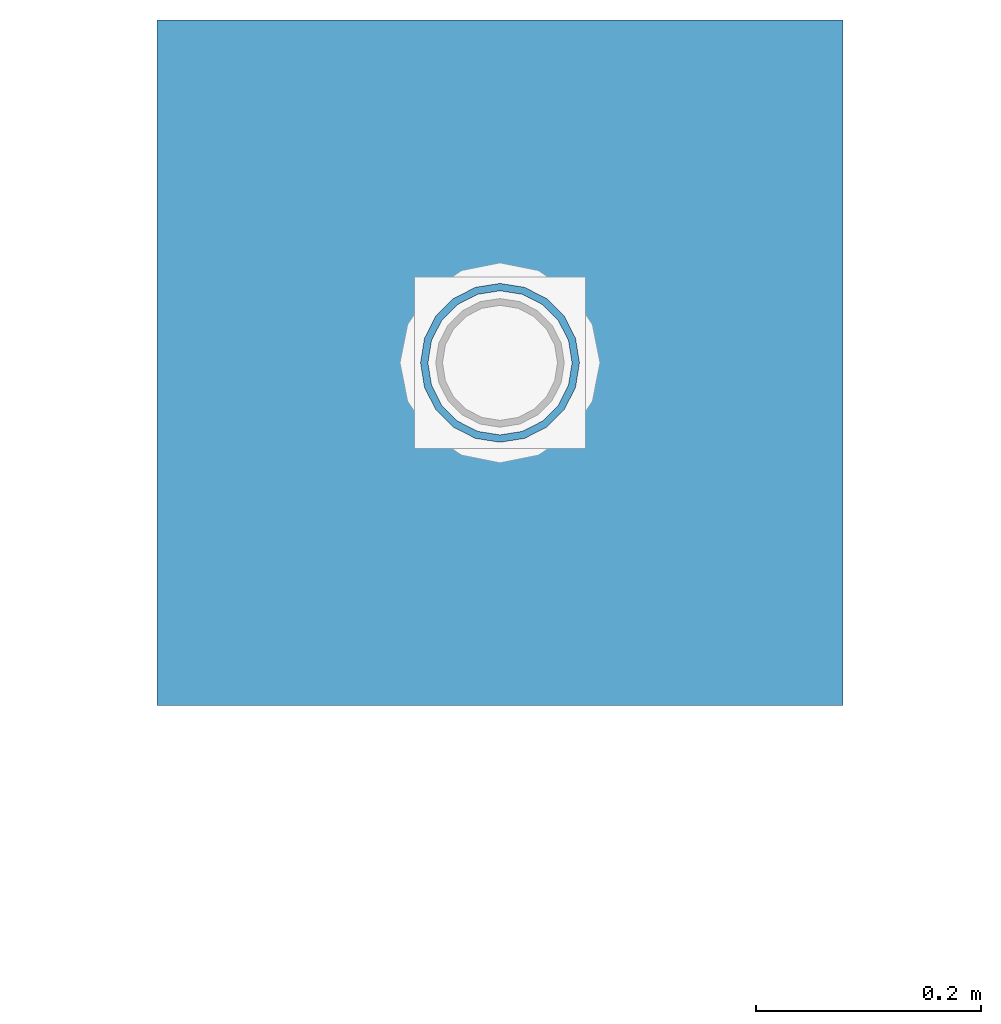
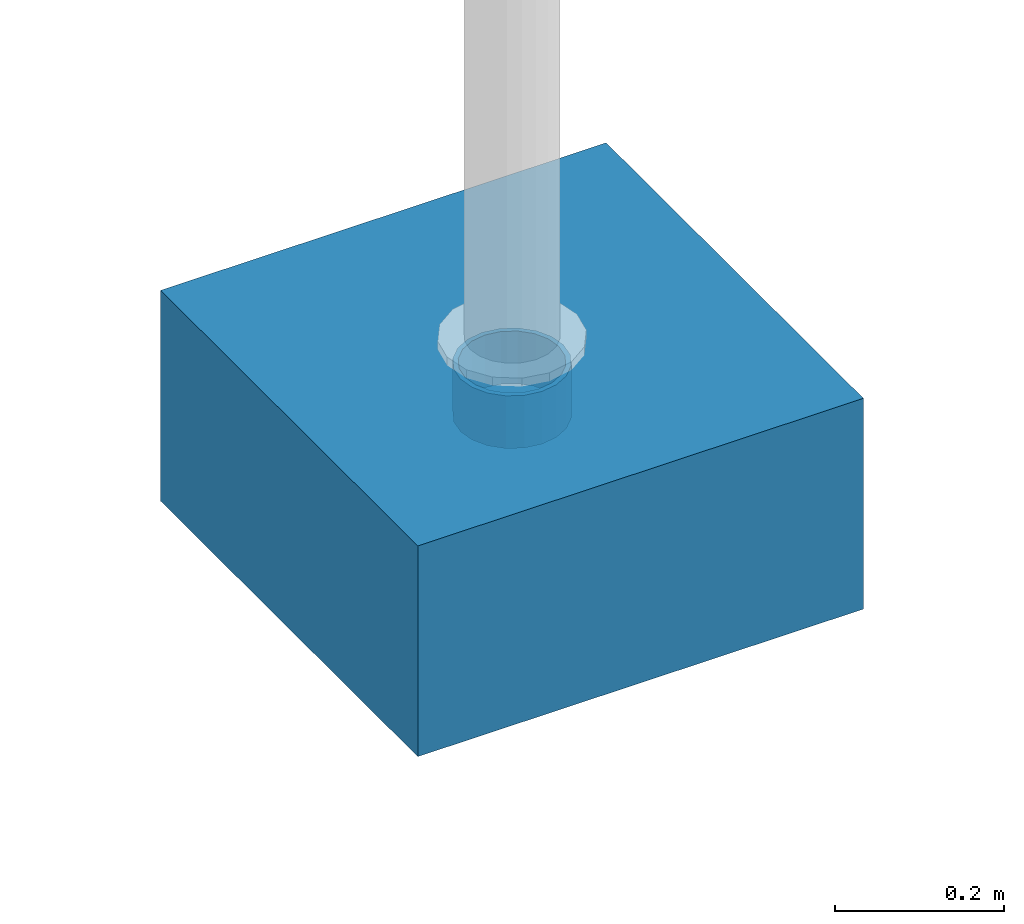
# One storey, part 1543 of 3843: 2 columns, 2 elements without a shape of their own.
"""IFC2X3 building model written with IfcOpenShell, lengths in millimetres."""

from ifc_helpers import new_model, si_unit, frame, origin_with_axes, place, context, subcontext, project, spatial, faceted_brep, material, type_object, element, aggregate, save


model = new_model("IFC2X3")

# Units and contexts
model_context = context("Model", 3, precision=1e-05, world=origin_with_axes())
body_context = subcontext(model_context, "Body", "Model", "MODEL_VIEW")
ifc_project = project(units=[si_unit("LENGTHUNIT", "METRE", prefix="MILLI"), si_unit("AREAUNIT", "SQUARE_METRE"), si_unit("VOLUMEUNIT", "CUBIC_METRE"), si_unit("MASSUNIT", "GRAM", prefix="KILO"), si_unit("TIMEUNIT", "SECOND"), si_unit("PLANEANGLEUNIT", "RADIAN"), si_unit("SOLIDANGLEUNIT", "STERADIAN"), si_unit("THERMODYNAMICTEMPERATUREUNIT", "DEGREE_CELSIUS"), si_unit("LUMINOUSINTENSITYUNIT", "LUMEN")], contexts=[model_context])

# Site, building, storey
site_placement = place(None, origin_with_axes())
site = spatial("IfcSite", under=ifc_project, at=site_placement, CompositionType="ELEMENT")
building_placement = place(site_placement, origin_with_axes())
building = spatial("IfcBuilding", under=site, at=building_placement, Name="Undefined", CompositionType="ELEMENT")
storey_placement = place(building_placement, origin_with_axes())
storey = spatial("IfcBuildingStorey", under=building, at=storey_placement, Name="Undefined", CompositionType="ELEMENT", Elevation=0.0)

# Assembly, column
assembly_1_placement = place(storey_placement, origin_with_axes())
assembly_1 = element("IfcElementAssembly", 1, at=assembly_1_placement, inside=storey, Name="PLATE", AssemblyPlace="NOTDEFINED", PredefinedType="RIGID_FRAME")
ifc_material_1 = material()
column_type_1 = type_object("IfcColumnType", Name="PIPE5SCH40", PredefinedType="NOTDEFINED")
column_1_placement = place(assembly_1_placement, frame((12915.2250135243, 106839.149780512, 30378.4), z_axis=(-1.0, 0.0, 0.0), x_axis=(0.0, 0.0, 1.0)))
column_1 = element("IfcColumn", 2, at=column_1_placement, type_object=column_type_1, material=ifc_material_1, Name="PIPE_SLEEVE", ObjectType="PIPE5SCH40", context=body_context, shape_type="Brep", body=[
    faceted_brep([(0.0, -64.0587999999998, 0.0), (0.0, -60.9235391660477, 19.7952578392724), (76.2000000000007, -60.9235391660477, 19.7952578392724), (76.2000000000007, -64.0587999999998, 0.0), (0.0, -51.8246578392655, 37.6528179195593), (76.2000000000007, -51.8246578392655, 37.6528179195593), (0.0, -37.6528179195529, 51.8246578392718), (76.2000000000007, -37.6528179195529, 51.8246578392718), (0.0, -19.795257839266, 60.9235391660477), (76.2000000000007, -19.795257839266, 60.9235391660477), (0.0, 0.0, 64.0587999999989), (76.2000000000007, 0.0, 64.0587999999989), (0.0, 19.795257839266, 60.9235391660477), (76.2000000000007, 19.795257839266, 60.9235391660477), (0.0, 37.6528179195529, 51.8246578392718), (76.2000000000007, 37.6528179195529, 51.8246578392718), (0.0, 51.8246578392655, 37.6528179195593), (76.2000000000007, 51.8246578392655, 37.6528179195593), (0.0, 60.9235391660477, 19.7952578392724), (76.2000000000007, 60.9235391660477, 19.7952578392724), (0.0, 64.0587999999998, 0.0), (76.2000000000007, 64.0587999999998, 0.0), (0.0, 60.9235391660477, -19.7952578392724), (76.2000000000007, 60.9235391660477, -19.7952578392724), (0.0, 51.8246578392655, -37.6528179195593), (76.2000000000007, 51.8246578392655, -37.6528179195593), (0.0, 37.6528179195529, -51.8246578392718), (76.2000000000007, 37.6528179195529, -51.8246578392718), (0.0, 19.795257839266, -60.9235391660477), (76.2000000000007, 19.795257839266, -60.9235391660477), (0.0, 0.0, -64.0587999999989), (76.2000000000007, 0.0, -64.0587999999989), (0.0, -19.795257839266, -60.9235391660477), (76.2000000000007, -19.795257839266, -60.9235391660477), (0.0, -37.6528179195529, -51.8246578392718), (76.2000000000007, -37.6528179195529, -51.8246578392718), (0.0, -51.8246578392655, -37.6528179195593), (76.2000000000007, -51.8246578392655, -37.6528179195593), (0.0, -60.9235391660477, -19.7952578392724), (76.2000000000007, -60.9235391660477, -19.7952578392724), (0.0, -70.6120000000001, 0.0), (0.0, -67.1560027286332, -21.8203080068051), (76.2000000000007, -67.1560027286332, -21.8203080068051), (76.2000000000007, -70.6120000000001, 0.0), (0.0, -57.1263080068038, -41.5046922348702), (76.2000000000007, -57.1263080068038, -41.5046922348702), (0.0, -41.5046922348765, -57.126308006802), (76.2000000000007, -41.5046922348765, -57.126308006802), (0.0, -21.8203080068042, -67.1560027286323), (76.2000000000007, -21.8203080068042, -67.1560027286323), (0.0, 0.0, -70.6119999999937), (76.2000000000007, 0.0, -70.6119999999937), (0.0, 21.8203080068042, -67.1560027286323), (76.2000000000007, 21.8203080068042, -67.1560027286323), (0.0, 41.5046922348765, -57.126308006802), (76.2000000000007, 41.5046922348765, -57.126308006802), (0.0, 57.1263080068038, -41.5046922348702), (76.2000000000007, 57.1263080068038, -41.5046922348702), (0.0, 67.1560027286332, -21.8203080068051), (76.2000000000007, 67.1560027286332, -21.8203080068051), (0.0, 70.6120000000001, 0.0), (76.2000000000007, 70.6120000000001, 0.0), (0.0, 67.1560027286332, 21.8203080068051), (76.2000000000007, 67.1560027286332, 21.8203080068051), (0.0, 57.1263080068038, 41.5046922348702), (76.2000000000007, 57.1263080068038, 41.5046922348702), (0.0, 41.5046922348765, 57.126308006802), (76.2000000000007, 41.5046922348765, 57.126308006802), (0.0, 21.8203080068042, 67.1560027286323), (76.2000000000007, 21.8203080068042, 67.1560027286323), (0.0, 0.0, 70.6119999999937), (76.2000000000007, 0.0, 70.6119999999937), (0.0, -21.8203080068042, 67.1560027286323), (76.2000000000007, -21.8203080068042, 67.1560027286323), (0.0, -41.5046922348765, 57.126308006802), (76.2000000000007, -41.5046922348765, 57.126308006802), (0.0, -57.1263080068038, 41.5046922348702), (76.2000000000007, -57.1263080068038, 41.5046922348702), (0.0, -67.1560027286332, 21.8203080068051), (76.2000000000007, -67.1560027286332, 21.8203080068051)], [[[0, 1, 2, 3]], [[1, 4, 5, 2]], [[4, 6, 7, 5]], [[6, 8, 9, 7]], [[8, 10, 11, 9]], [[10, 12, 13, 11]], [[12, 14, 15, 13]], [[14, 16, 17, 15]], [[16, 18, 19, 17]], [[18, 20, 21, 19]], [[20, 22, 23, 21]], [[22, 24, 25, 23]], [[24, 26, 27, 25]], [[26, 28, 29, 27]], [[28, 30, 31, 29]], [[30, 32, 33, 31]], [[32, 34, 35, 33]], [[34, 36, 37, 35]], [[36, 38, 39, 37]], [[38, 0, 3, 39]], [[40, 41, 42, 43]], [[41, 44, 45, 42]], [[44, 46, 47, 45]], [[46, 48, 49, 47]], [[48, 50, 51, 49]], [[50, 52, 53, 51]], [[52, 54, 55, 53]], [[54, 56, 57, 55]], [[56, 58, 59, 57]], [[58, 60, 61, 59]], [[60, 62, 63, 61]], [[62, 64, 65, 63]], [[64, 66, 67, 65]], [[66, 68, 69, 67]], [[68, 70, 71, 69]], [[70, 72, 73, 71]], [[72, 74, 75, 73]], [[74, 76, 77, 75]], [[76, 78, 79, 77]], [[78, 40, 43, 79]], [[45, 47, 49, 51, 53, 55, 57, 59, 61, 63, 65, 67, 69, 71, 73, 75, 77, 79, 43, 42], [5, 7, 9, 11, 13, 15, 17, 19, 21, 23, 25, 27, 29, 31, 33, 35, 37, 39, 3, 2]], [[78, 76, 74, 72, 70, 68, 66, 64, 62, 60, 58, 56, 54, 52, 50, 48, 46, 44, 41, 40], [38, 36, 34, 32, 30, 28, 26, 24, 22, 20, 18, 16, 14, 12, 10, 8, 6, 4, 1, 0]]]),
])
aggregate(assembly_1, [column_1])

assembly_2_placement = place(storey_placement, origin_with_axes())
assembly_2 = element("IfcElementAssembly", 3, at=assembly_2_placement, inside=storey, Name="CONC_COL.", AssemblyPlace="NOTDEFINED", PredefinedType="REINFORCEMENT_UNIT")
ifc_material_2 = material(Name="CONCRETE/3000")
column_type_2 = type_object("IfcColumnType", PredefinedType="NOTDEFINED")
column_2_placement = place(assembly_2_placement, frame((12915.2250135243, 106839.149780512, 30175.2), z_axis=(-1.0, 0.0, 0.0), x_axis=(0.0, 0.0, 1.0)))
column_2 = element("IfcColumn", 4, at=column_2_placement, type_object=column_type_2, material=ifc_material_2, Name="CONC_COL.", context=body_context, shape_type="Brep", body=[
    faceted_brep([(0.0, 304.8, -304.800000000003), (0.0, 304.8, 304.800000000003), (304.799999999999, 304.8, 304.800000000003), (304.799999999999, 304.8, -304.800000000003), (0.0, -304.8, 304.800000000003), (304.799999999999, -304.8, 304.800000000003), (0.0, -304.8, -304.800000000003), (304.799999999999, -304.8, -304.800000000003)], [[[0, 1, 2, 3]], [[1, 4, 5, 2]], [[4, 6, 7, 5]], [[6, 0, 3, 7]], [[5, 7, 3, 2]], [[6, 4, 1, 0]]]),
])
aggregate(assembly_2, [column_2])

save(model, "model.ifc")
